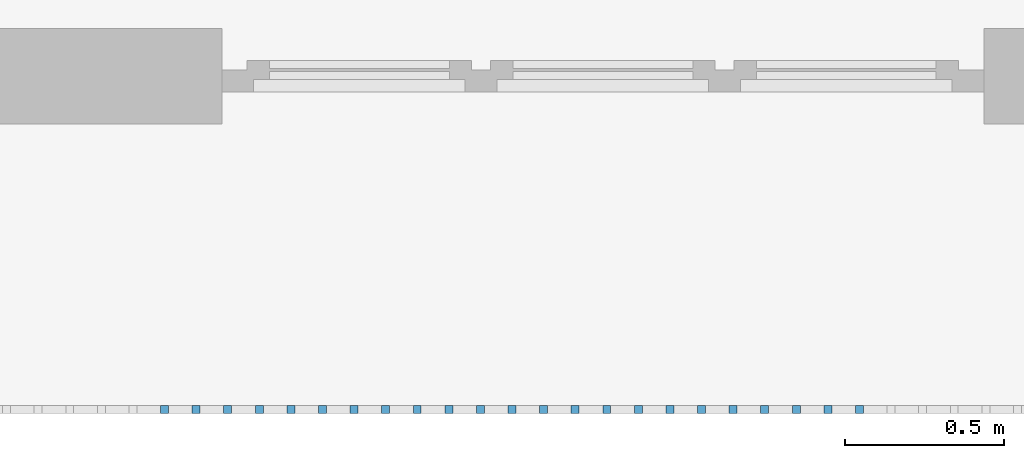
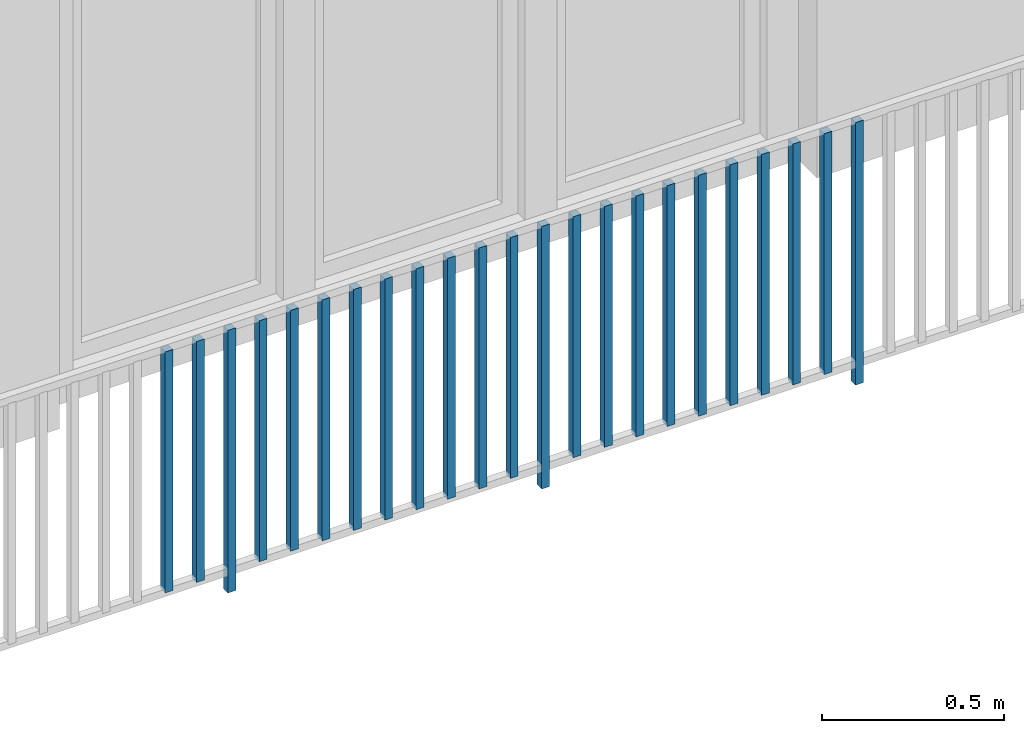
# One storey, part 33 of 54: 23 building element parts, 1 element without a shape of its own.
"""IFC4 building model written with IfcOpenShell, lengths in metres."""

from ifc_helpers import new_model, entity, si_unit, converted_unit, derived_unit, direction, frame, origin_with_axes, place, context, subcontext, project, spatial, polygons, material, type_object, element, aggregate, save


model = new_model("IFC4")

# Units and contexts
model_context = context("Model", 3, precision=1e-05, world=origin_with_axes(), true_north=direction((0.0, 1.0)))
body_context = subcontext(model_context, "Body", "Model", "MODEL_VIEW")
ifc_project = project(units=[si_unit("LENGTHUNIT", "METRE"), si_unit("AREAUNIT", "SQUARE_METRE"), si_unit("VOLUMEUNIT", "CUBIC_METRE"), converted_unit("PLANEANGLEUNIT", "DEGREE", entity("IfcPlaneAngleMeasure", 0.0174532925199), si_unit("PLANEANGLEUNIT", "RADIAN"), dimensions=[0, 0, 0, 0, 0, 0, 0]), converted_unit("TIMEUNIT", "Year", entity("IfcTimeMeasure", 31556926.0), si_unit("TIMEUNIT", "SECOND"), dimensions=[0, 0, 1, 0, 0, 0, 0]), si_unit("MASSUNIT", "GRAM", prefix="KILO"), si_unit("THERMODYNAMICTEMPERATUREUNIT", "DEGREE_CELSIUS"), si_unit("LUMINOUSINTENSITYUNIT", "LUMEN"), si_unit("ENERGYUNIT", "JOULE", prefix="MEGA"), derived_unit("THERMALCONDUCTANCEUNIT", [(si_unit("POWERUNIT", "WATT"), 1), (si_unit("LENGTHUNIT", "METRE"), -1), (si_unit("THERMODYNAMICTEMPERATUREUNIT", "KELVIN"), -1)]), derived_unit("SPECIFICHEATCAPACITYUNIT", [(si_unit("ENERGYUNIT", "JOULE"), 1), (si_unit("MASSUNIT", "GRAM", prefix="KILO"), -1), (si_unit("THERMODYNAMICTEMPERATUREUNIT", "KELVIN"), -1)]), derived_unit("MASSDENSITYUNIT", [(si_unit("MASSUNIT", "GRAM", prefix="KILO"), 1), (si_unit("VOLUMEUNIT", "CUBIC_METRE"), -1)])], contexts=[model_context])

# Site, building, storey, space
site_placement = place(None, origin_with_axes())
site = spatial("IfcSite", under=ifc_project, at=site_placement, CompositionType="ELEMENT")
building_placement = place(site_placement, origin_with_axes())
building = spatial("IfcBuilding", under=site, at=building_placement, CompositionType="ELEMENT")
storey_placement = place(building_placement, frame((0.0, 0.0, 6.29), z_axis=(0.0, 0.0, 1.0), x_axis=(1.0, 0.0, 0.0)))
storey = spatial("IfcBuildingStorey", under=building, at=storey_placement, Name="2. Geschoss", CompositionType="ELEMENT", Elevation=6.29)
space_placement = place(storey_placement, frame((10.2378006196, 9.82118769833, 0.0), z_axis=(0.0, 0.0, 1.0), x_axis=(-1.0, 0.0, 0.0)))
space = spatial("IfcSpace", under=storey, at=space_placement, CompositionType="ELEMENT", PredefinedType="EXTERNAL")

# Railing, building element parts
railing_type = type_object("IfcRailingType", PredefinedType="NOTDEFINED")
railing_placement = place(space_placement, frame((0.0, -7.06315681498e-08, 0.0), z_axis=(0.0, 0.0, 1.0), x_axis=(-1.0, 0.0, 0.0)))
railing = element("IfcRailing", 1, at=railing_placement, inside=space, type_object=railing_type, PredefinedType="NOTDEFINED")
ifc_material = material()
building_element_part_1_placement = place(railing_placement, origin_with_axes())
building_element_part_1 = element("IfcBuildingElementPart", 2, at=building_element_part_1_placement, material=ifc_material, PredefinedType="NOTDEFINED", context=body_context, shape_type="Tessellation", body=[
    polygons([(-17.0977608696, -20.6625, 0.07), (-17.0977608696, -20.6375, 0.07), (-17.0977608696, -20.6375, 0.8775), (-17.0977608696, -20.6625, 0.8775), (-17.1227608696, -20.6625, 0.07), (-17.1227608696, -20.6375, 0.07), (-17.1227608696, -20.6375, 0.8775), (-17.1227608696, -20.6625, 0.8775)], [[[1, 2, 3, 4]], [[1, 5, 6, 2]], [[2, 6, 7, 3]], [[4, 3, 7, 8]], [[5, 1, 4, 8]], [[6, 5, 8, 7]]], closed=True),
])
building_element_part_2_placement = place(railing_placement, origin_with_axes())
building_element_part_2 = element("IfcBuildingElementPart", 3, at=building_element_part_2_placement, material=ifc_material, PredefinedType="NOTDEFINED", context=body_context, shape_type="Tessellation", body=[
    polygons([(-16.9982826087, -20.6625, 0.07), (-16.9982826087, -20.6375, 0.07), (-16.9982826087, -20.6375, 0.8775), (-16.9982826087, -20.6625, 0.8775), (-17.0232826087, -20.6625, 0.07), (-17.0232826087, -20.6375, 0.07), (-17.0232826087, -20.6375, 0.8775), (-17.0232826087, -20.6625, 0.8775)], [[[1, 2, 3, 4]], [[1, 5, 6, 2]], [[2, 6, 7, 3]], [[4, 3, 7, 8]], [[5, 1, 4, 8]], [[6, 5, 8, 7]]], closed=True),
])
building_element_part_3_placement = place(railing_placement, origin_with_axes())
building_element_part_3 = element("IfcBuildingElementPart", 4, at=building_element_part_3_placement, material=ifc_material, PredefinedType="NOTDEFINED", context=body_context, shape_type="Tessellation", body=[
    polygons([(-16.8988043478, -20.6625, 0.0), (-16.8988043478, -20.6375, 0.0), (-16.8988043478, -20.6375, 0.88), (-16.8988043478, -20.6625, 0.88), (-16.9238043478, -20.6625, 0.0), (-16.9238043478, -20.6375, 0.0), (-16.9238043478, -20.6375, 0.88), (-16.9238043478, -20.6625, 0.88)], [[[1, 2, 3, 4]], [[1, 5, 6, 2]], [[2, 6, 7, 3]], [[4, 3, 7, 8]], [[5, 1, 4, 8]], [[6, 5, 8, 7]]], closed=True),
])
building_element_part_4_placement = place(railing_placement, origin_with_axes())
building_element_part_4 = element("IfcBuildingElementPart", 5, at=building_element_part_4_placement, material=ifc_material, PredefinedType="NOTDEFINED", context=body_context, shape_type="Tessellation", body=[
    polygons([(-16.799326087, -20.6625, 0.07), (-16.799326087, -20.6375, 0.07), (-16.799326087, -20.6375, 0.8775), (-16.799326087, -20.6625, 0.8775), (-16.824326087, -20.6625, 0.07), (-16.824326087, -20.6375, 0.07), (-16.824326087, -20.6375, 0.8775), (-16.824326087, -20.6625, 0.8775)], [[[1, 2, 3, 4]], [[1, 5, 6, 2]], [[2, 6, 7, 3]], [[4, 3, 7, 8]], [[5, 1, 4, 8]], [[6, 5, 8, 7]]], closed=True),
])
building_element_part_5_placement = place(railing_placement, origin_with_axes())
building_element_part_5 = element("IfcBuildingElementPart", 6, at=building_element_part_5_placement, material=ifc_material, PredefinedType="NOTDEFINED", context=body_context, shape_type="Tessellation", body=[
    polygons([(-16.6998478261, -20.6625, 0.07), (-16.6998478261, -20.6375, 0.07), (-16.6998478261, -20.6375, 0.8775), (-16.6998478261, -20.6625, 0.8775), (-16.7248478261, -20.6625, 0.07), (-16.7248478261, -20.6375, 0.07), (-16.7248478261, -20.6375, 0.8775), (-16.7248478261, -20.6625, 0.8775)], [[[1, 2, 3, 4]], [[1, 5, 6, 2]], [[2, 6, 7, 3]], [[4, 3, 7, 8]], [[5, 1, 4, 8]], [[6, 5, 8, 7]]], closed=True),
])
building_element_part_6_placement = place(railing_placement, origin_with_axes())
building_element_part_6 = element("IfcBuildingElementPart", 7, at=building_element_part_6_placement, material=ifc_material, PredefinedType="NOTDEFINED", context=body_context, shape_type="Tessellation", body=[
    polygons([(-16.6003695652, -20.6625, 0.07), (-16.6003695652, -20.6375, 0.07), (-16.6003695652, -20.6375, 0.8775), (-16.6003695652, -20.6625, 0.8775), (-16.6253695652, -20.6625, 0.07), (-16.6253695652, -20.6375, 0.07), (-16.6253695652, -20.6375, 0.8775), (-16.6253695652, -20.6625, 0.8775)], [[[1, 2, 3, 4]], [[1, 5, 6, 2]], [[2, 6, 7, 3]], [[4, 3, 7, 8]], [[5, 1, 4, 8]], [[6, 5, 8, 7]]], closed=True),
])
building_element_part_7_placement = place(railing_placement, origin_with_axes())
building_element_part_7 = element("IfcBuildingElementPart", 8, at=building_element_part_7_placement, material=ifc_material, PredefinedType="NOTDEFINED", context=body_context, shape_type="Tessellation", body=[
    polygons([(-16.5008913043, -20.6625, 0.07), (-16.5008913043, -20.6375, 0.07), (-16.5008913043, -20.6375, 0.8775), (-16.5008913043, -20.6625, 0.8775), (-16.5258913043, -20.6625, 0.07), (-16.5258913043, -20.6375, 0.07), (-16.5258913043, -20.6375, 0.8775), (-16.5258913043, -20.6625, 0.8775)], [[[1, 2, 3, 4]], [[1, 5, 6, 2]], [[2, 6, 7, 3]], [[4, 3, 7, 8]], [[5, 1, 4, 8]], [[6, 5, 8, 7]]], closed=True),
])
building_element_part_8_placement = place(railing_placement, origin_with_axes())
building_element_part_8 = element("IfcBuildingElementPart", 9, at=building_element_part_8_placement, material=ifc_material, PredefinedType="NOTDEFINED", context=body_context, shape_type="Tessellation", body=[
    polygons([(-16.4014130435, -20.6625, 0.07), (-16.4014130435, -20.6375, 0.07), (-16.4014130435, -20.6375, 0.8775), (-16.4014130435, -20.6625, 0.8775), (-16.4264130435, -20.6625, 0.07), (-16.4264130435, -20.6375, 0.07), (-16.4264130435, -20.6375, 0.8775), (-16.4264130435, -20.6625, 0.8775)], [[[1, 2, 3, 4]], [[1, 5, 6, 2]], [[2, 6, 7, 3]], [[4, 3, 7, 8]], [[5, 1, 4, 8]], [[6, 5, 8, 7]]], closed=True),
])
building_element_part_9_placement = place(railing_placement, origin_with_axes())
building_element_part_9 = element("IfcBuildingElementPart", 10, at=building_element_part_9_placement, material=ifc_material, PredefinedType="NOTDEFINED", context=body_context, shape_type="Tessellation", body=[
    polygons([(-16.3019347826, -20.6625, 0.07), (-16.3019347826, -20.6375, 0.07), (-16.3019347826, -20.6375, 0.8775), (-16.3019347826, -20.6625, 0.8775), (-16.3269347826, -20.6625, 0.07), (-16.3269347826, -20.6375, 0.07), (-16.3269347826, -20.6375, 0.8775), (-16.3269347826, -20.6625, 0.8775)], [[[1, 2, 3, 4]], [[1, 5, 6, 2]], [[2, 6, 7, 3]], [[4, 3, 7, 8]], [[5, 1, 4, 8]], [[6, 5, 8, 7]]], closed=True),
])
building_element_part_10_placement = place(railing_placement, origin_with_axes())
building_element_part_10 = element("IfcBuildingElementPart", 11, at=building_element_part_10_placement, material=ifc_material, PredefinedType="NOTDEFINED", context=body_context, shape_type="Tessellation", body=[
    polygons([(-16.2024565217, -20.6625, 0.07), (-16.2024565217, -20.6375, 0.07), (-16.2024565217, -20.6375, 0.8775), (-16.2024565217, -20.6625, 0.8775), (-16.2274565217, -20.6625, 0.07), (-16.2274565217, -20.6375, 0.07), (-16.2274565217, -20.6375, 0.8775), (-16.2274565217, -20.6625, 0.8775)], [[[1, 2, 3, 4]], [[1, 5, 6, 2]], [[2, 6, 7, 3]], [[4, 3, 7, 8]], [[5, 1, 4, 8]], [[6, 5, 8, 7]]], closed=True),
])
building_element_part_11_placement = place(railing_placement, origin_with_axes())
building_element_part_11 = element("IfcBuildingElementPart", 12, at=building_element_part_11_placement, material=ifc_material, PredefinedType="NOTDEFINED", context=body_context, shape_type="Tessellation", body=[
    polygons([(-16.1029782609, -20.6625, 0.07), (-16.1029782609, -20.6375, 0.07), (-16.1029782609, -20.6375, 0.8775), (-16.1029782609, -20.6625, 0.8775), (-16.1279782609, -20.6625, 0.07), (-16.1279782609, -20.6375, 0.07), (-16.1279782609, -20.6375, 0.8775), (-16.1279782609, -20.6625, 0.8775)], [[[1, 2, 3, 4]], [[1, 5, 6, 2]], [[2, 6, 7, 3]], [[4, 3, 7, 8]], [[5, 1, 4, 8]], [[6, 5, 8, 7]]], closed=True),
])
building_element_part_12_placement = place(railing_placement, origin_with_axes())
building_element_part_12 = element("IfcBuildingElementPart", 13, at=building_element_part_12_placement, material=ifc_material, PredefinedType="NOTDEFINED", context=body_context, shape_type="Tessellation", body=[
    polygons([(-16.0035, -20.6625, 0.07), (-16.0035, -20.6375, 0.07), (-16.0035, -20.6375, 0.8775), (-16.0035, -20.6625, 0.8775), (-16.0285, -20.6625, 0.07), (-16.0285, -20.6375, 0.07), (-16.0285, -20.6375, 0.8775), (-16.0285, -20.6625, 0.8775)], [[[1, 2, 3, 4]], [[1, 5, 6, 2]], [[2, 6, 7, 3]], [[4, 3, 7, 8]], [[5, 1, 4, 8]], [[6, 5, 8, 7]]], closed=True),
])
building_element_part_13_placement = place(railing_placement, origin_with_axes())
building_element_part_13 = element("IfcBuildingElementPart", 14, at=building_element_part_13_placement, material=ifc_material, PredefinedType="NOTDEFINED", context=body_context, shape_type="Tessellation", body=[
    polygons([(-15.9040217391, -20.6625, 0.0), (-15.9040217391, -20.6375, 0.0), (-15.9040217391, -20.6375, 0.88), (-15.9040217391, -20.6625, 0.88), (-15.9290217391, -20.6625, 0.0), (-15.9290217391, -20.6375, 0.0), (-15.9290217391, -20.6375, 0.88), (-15.9290217391, -20.6625, 0.88)], [[[1, 2, 3, 4]], [[1, 5, 6, 2]], [[2, 6, 7, 3]], [[4, 3, 7, 8]], [[5, 1, 4, 8]], [[6, 5, 8, 7]]], closed=True),
])
building_element_part_14_placement = place(railing_placement, origin_with_axes())
building_element_part_14 = element("IfcBuildingElementPart", 15, at=building_element_part_14_placement, material=ifc_material, PredefinedType="NOTDEFINED", context=body_context, shape_type="Tessellation", body=[
    polygons([(-15.8045434783, -20.6625, 0.07), (-15.8045434783, -20.6375, 0.07), (-15.8045434783, -20.6375, 0.8775), (-15.8045434783, -20.6625, 0.8775), (-15.8295434783, -20.6625, 0.07), (-15.8295434783, -20.6375, 0.07), (-15.8295434783, -20.6375, 0.8775), (-15.8295434783, -20.6625, 0.8775)], [[[1, 2, 3, 4]], [[1, 5, 6, 2]], [[2, 6, 7, 3]], [[4, 3, 7, 8]], [[5, 1, 4, 8]], [[6, 5, 8, 7]]], closed=True),
])
building_element_part_15_placement = place(railing_placement, origin_with_axes())
building_element_part_15 = element("IfcBuildingElementPart", 16, at=building_element_part_15_placement, material=ifc_material, PredefinedType="NOTDEFINED", context=body_context, shape_type="Tessellation", body=[
    polygons([(-15.7050652174, -20.6625, 0.07), (-15.7050652174, -20.6375, 0.07), (-15.7050652174, -20.6375, 0.8775), (-15.7050652174, -20.6625, 0.8775), (-15.7300652174, -20.6625, 0.07), (-15.7300652174, -20.6375, 0.07), (-15.7300652174, -20.6375, 0.8775), (-15.7300652174, -20.6625, 0.8775)], [[[1, 2, 3, 4]], [[1, 5, 6, 2]], [[2, 6, 7, 3]], [[4, 3, 7, 8]], [[5, 1, 4, 8]], [[6, 5, 8, 7]]], closed=True),
])
building_element_part_16_placement = place(railing_placement, origin_with_axes())
building_element_part_16 = element("IfcBuildingElementPart", 17, at=building_element_part_16_placement, material=ifc_material, PredefinedType="NOTDEFINED", context=body_context, shape_type="Tessellation", body=[
    polygons([(-15.6055869565, -20.6625, 0.07), (-15.6055869565, -20.6375, 0.07), (-15.6055869565, -20.6375, 0.8775), (-15.6055869565, -20.6625, 0.8775), (-15.6305869565, -20.6625, 0.07), (-15.6305869565, -20.6375, 0.07), (-15.6305869565, -20.6375, 0.8775), (-15.6305869565, -20.6625, 0.8775)], [[[1, 2, 3, 4]], [[1, 5, 6, 2]], [[2, 6, 7, 3]], [[4, 3, 7, 8]], [[5, 1, 4, 8]], [[6, 5, 8, 7]]], closed=True),
])
building_element_part_17_placement = place(railing_placement, origin_with_axes())
building_element_part_17 = element("IfcBuildingElementPart", 18, at=building_element_part_17_placement, material=ifc_material, PredefinedType="NOTDEFINED", context=body_context, shape_type="Tessellation", body=[
    polygons([(-15.5061086957, -20.6625, 0.07), (-15.5061086957, -20.6375, 0.07), (-15.5061086957, -20.6375, 0.8775), (-15.5061086957, -20.6625, 0.8775), (-15.5311086957, -20.6625, 0.07), (-15.5311086957, -20.6375, 0.07), (-15.5311086957, -20.6375, 0.8775), (-15.5311086957, -20.6625, 0.8775)], [[[1, 2, 3, 4]], [[1, 5, 6, 2]], [[2, 6, 7, 3]], [[4, 3, 7, 8]], [[5, 1, 4, 8]], [[6, 5, 8, 7]]], closed=True),
])
building_element_part_18_placement = place(railing_placement, origin_with_axes())
building_element_part_18 = element("IfcBuildingElementPart", 19, at=building_element_part_18_placement, material=ifc_material, PredefinedType="NOTDEFINED", context=body_context, shape_type="Tessellation", body=[
    polygons([(-15.4066304348, -20.6625, 0.07), (-15.4066304348, -20.6375, 0.07), (-15.4066304348, -20.6375, 0.8775), (-15.4066304348, -20.6625, 0.8775), (-15.4316304348, -20.6625, 0.07), (-15.4316304348, -20.6375, 0.07), (-15.4316304348, -20.6375, 0.8775), (-15.4316304348, -20.6625, 0.8775)], [[[1, 2, 3, 4]], [[1, 5, 6, 2]], [[2, 6, 7, 3]], [[4, 3, 7, 8]], [[5, 1, 4, 8]], [[6, 5, 8, 7]]], closed=True),
])
building_element_part_19_placement = place(railing_placement, origin_with_axes())
building_element_part_19 = element("IfcBuildingElementPart", 20, at=building_element_part_19_placement, material=ifc_material, PredefinedType="NOTDEFINED", context=body_context, shape_type="Tessellation", body=[
    polygons([(-15.3071521739, -20.6625, 0.07), (-15.3071521739, -20.6375, 0.07), (-15.3071521739, -20.6375, 0.8775), (-15.3071521739, -20.6625, 0.8775), (-15.3321521739, -20.6625, 0.07), (-15.3321521739, -20.6375, 0.07), (-15.3321521739, -20.6375, 0.8775), (-15.3321521739, -20.6625, 0.8775)], [[[1, 2, 3, 4]], [[1, 5, 6, 2]], [[2, 6, 7, 3]], [[4, 3, 7, 8]], [[5, 1, 4, 8]], [[6, 5, 8, 7]]], closed=True),
])
building_element_part_20_placement = place(railing_placement, origin_with_axes())
building_element_part_20 = element("IfcBuildingElementPart", 21, at=building_element_part_20_placement, material=ifc_material, PredefinedType="NOTDEFINED", context=body_context, shape_type="Tessellation", body=[
    polygons([(-15.207673913, -20.6625, 0.07), (-15.207673913, -20.6375, 0.07), (-15.207673913, -20.6375, 0.8775), (-15.207673913, -20.6625, 0.8775), (-15.232673913, -20.6625, 0.07), (-15.232673913, -20.6375, 0.07), (-15.232673913, -20.6375, 0.8775), (-15.232673913, -20.6625, 0.8775)], [[[1, 2, 3, 4]], [[1, 5, 6, 2]], [[2, 6, 7, 3]], [[4, 3, 7, 8]], [[5, 1, 4, 8]], [[6, 5, 8, 7]]], closed=True),
])
building_element_part_21_placement = place(railing_placement, origin_with_axes())
building_element_part_21 = element("IfcBuildingElementPart", 22, at=building_element_part_21_placement, material=ifc_material, PredefinedType="NOTDEFINED", context=body_context, shape_type="Tessellation", body=[
    polygons([(-15.1081956522, -20.6625, 0.07), (-15.1081956522, -20.6375, 0.07), (-15.1081956522, -20.6375, 0.8775), (-15.1081956522, -20.6625, 0.8775), (-15.1331956522, -20.6625, 0.07), (-15.1331956522, -20.6375, 0.07), (-15.1331956522, -20.6375, 0.8775), (-15.1331956522, -20.6625, 0.8775)], [[[1, 2, 3, 4]], [[1, 5, 6, 2]], [[2, 6, 7, 3]], [[4, 3, 7, 8]], [[5, 1, 4, 8]], [[6, 5, 8, 7]]], closed=True),
])
building_element_part_22_placement = place(railing_placement, origin_with_axes())
building_element_part_22 = element("IfcBuildingElementPart", 23, at=building_element_part_22_placement, material=ifc_material, PredefinedType="NOTDEFINED", context=body_context, shape_type="Tessellation", body=[
    polygons([(-15.0087173913, -20.6625, 0.07), (-15.0087173913, -20.6375, 0.07), (-15.0087173913, -20.6375, 0.8775), (-15.0087173913, -20.6625, 0.8775), (-15.0337173913, -20.6625, 0.07), (-15.0337173913, -20.6375, 0.07), (-15.0337173913, -20.6375, 0.8775), (-15.0337173913, -20.6625, 0.8775)], [[[1, 2, 3, 4]], [[1, 5, 6, 2]], [[2, 6, 7, 3]], [[4, 3, 7, 8]], [[5, 1, 4, 8]], [[6, 5, 8, 7]]], closed=True),
])
building_element_part_23_placement = place(railing_placement, origin_with_axes())
building_element_part_23 = element("IfcBuildingElementPart", 24, at=building_element_part_23_placement, material=ifc_material, PredefinedType="NOTDEFINED", context=body_context, shape_type="Tessellation", body=[
    polygons([(-14.9092391304, -20.6625, 0.0), (-14.9092391304, -20.6375, 0.0), (-14.9092391304, -20.6375, 0.88), (-14.9092391304, -20.6625, 0.88), (-14.9342391304, -20.6625, 0.0), (-14.9342391304, -20.6375, 0.0), (-14.9342391304, -20.6375, 0.88), (-14.9342391304, -20.6625, 0.88)], [[[1, 2, 3, 4]], [[1, 5, 6, 2]], [[2, 6, 7, 3]], [[4, 3, 7, 8]], [[5, 1, 4, 8]], [[6, 5, 8, 7]]], closed=True),
])
aggregate(railing, [building_element_part_1, building_element_part_2, building_element_part_3, building_element_part_4, building_element_part_5, building_element_part_6, building_element_part_7, building_element_part_8, building_element_part_9, building_element_part_10, building_element_part_11, building_element_part_12, building_element_part_13, building_element_part_14, building_element_part_15, building_element_part_16, building_element_part_17, building_element_part_18, building_element_part_19, building_element_part_20, building_element_part_21, building_element_part_22, building_element_part_23])

save(model, "model.ifc")
